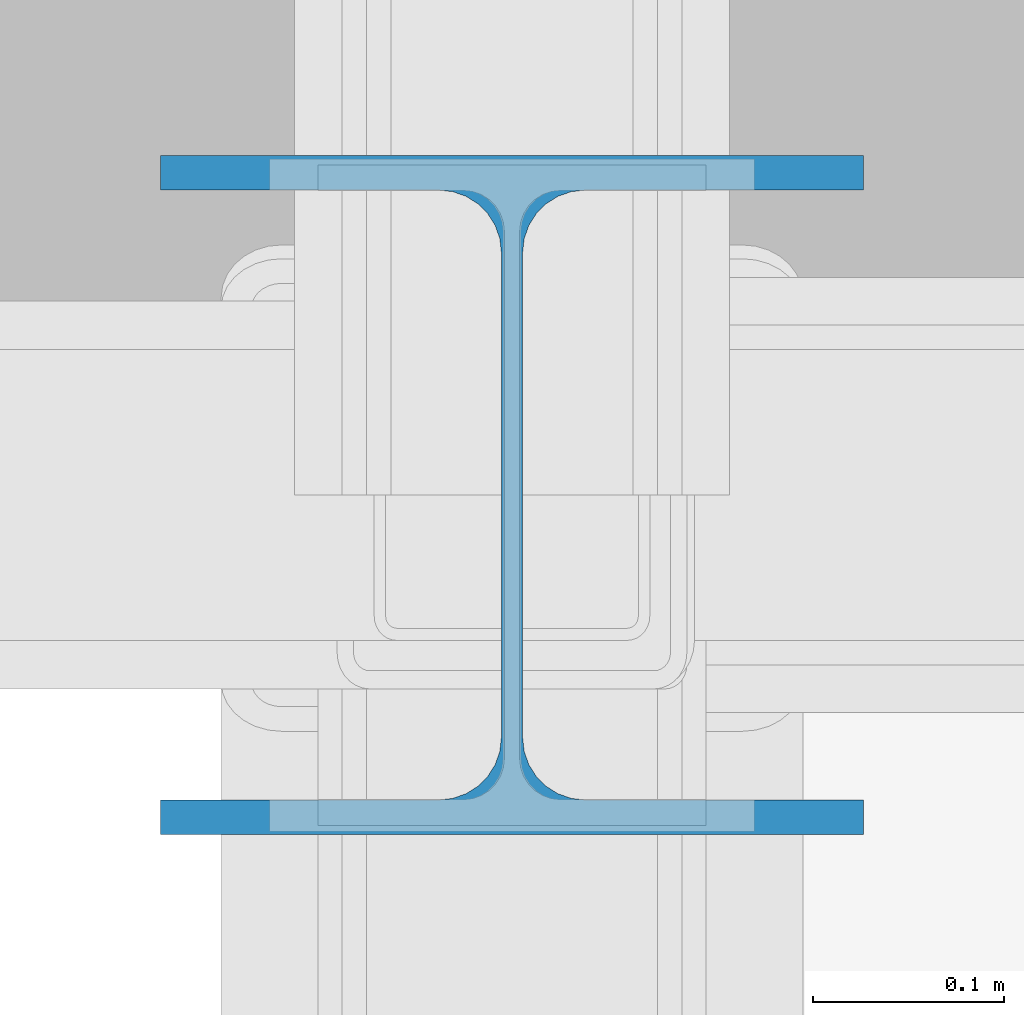
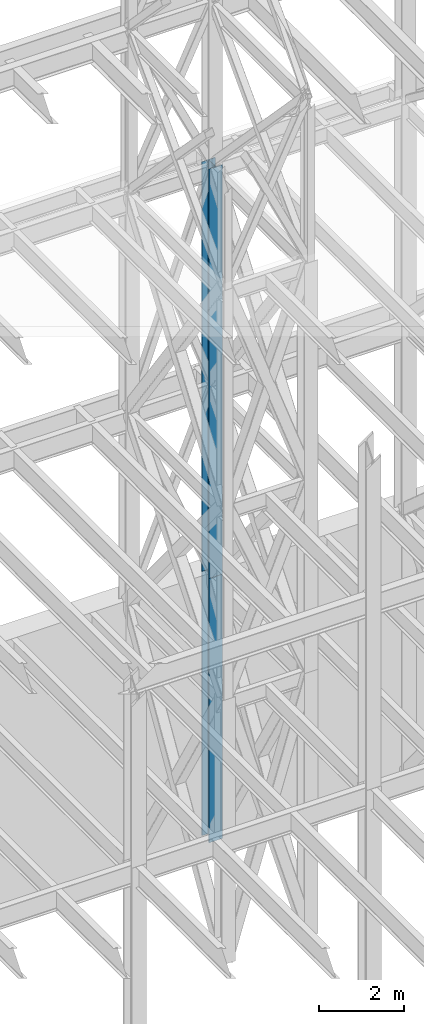
# One storey, part 109 of 150: 2 columns.
"""IFC2X3 building model written with IfcOpenShell, lengths in millimetres."""

from ifc_helpers import new_model, si_unit, frame, origin_with_axes, origin_2d_with_axis, place, context, subcontext, project, spatial, i_section, extrude, material, type_object, element, save


model = new_model("IFC2X3")

# Units and contexts
model_context = context("Model", 3, precision=1e-05, world=origin_with_axes())
body_context = subcontext(model_context, "Body", "Model", "MODEL_VIEW")
ifc_project = project(units=[si_unit("LENGTHUNIT", "METRE", prefix="MILLI"), si_unit("AREAUNIT", "SQUARE_METRE"), si_unit("VOLUMEUNIT", "CUBIC_METRE"), si_unit("MASSUNIT", "GRAM", prefix="KILO"), si_unit("TIMEUNIT", "SECOND"), si_unit("PLANEANGLEUNIT", "RADIAN"), si_unit("SOLIDANGLEUNIT", "STERADIAN"), si_unit("THERMODYNAMICTEMPERATUREUNIT", "DEGREE_CELSIUS"), si_unit("LUMINOUSINTENSITYUNIT", "LUMEN")], contexts=[model_context])

# Site, building, storey
site_placement = place(None, origin_with_axes())
site = spatial("IfcSite", under=ifc_project, at=site_placement, CompositionType="ELEMENT")
building_placement = place(site_placement, origin_with_axes())
building = spatial("IfcBuilding", under=site, at=building_placement, Name="Undefined", CompositionType="ELEMENT")
storey_placement = place(building_placement, origin_with_axes())
storey = spatial("IfcBuildingStorey", under=building, at=storey_placement, Name="Undefined", CompositionType="ELEMENT", Elevation=0.0)

# Columns
ifc_material = material(Name="STEEL/A992")
column_type = type_object("IfcColumnType", Name="W14X90", PredefinedType="NOTDEFINED")
column_1_placement = place(storey_placement, frame((76923.9, 31877.0, 23774.4), z_axis=(0.0, 0.0, 1.0), x_axis=(1.0, 0.0, 0.0)))
element("IfcColumn", 1, at=column_1_placement, inside=storey, type_object=column_type, material=ifc_material, Name="COLUMN", ObjectType="W14X90", context=body_context, shape_type="SweptSolid", body=[
    extrude(i_section(OverallWidth=368.3, OverallDepth=355.6, WebThickness=11.1125, FlangeThickness=18.034, FilletRadius=32.7659, at=origin_2d_with_axis()), frame((0.0, 0.0, 11811.0), z_axis=(0.0, 0.0, -1.0), x_axis=(-1.0, 0.0, 0.0)), (0.0, 0.0, 1.0), 11811.0),
])
column_2_placement = place(storey_placement, frame((76923.9, 31877.0, 16154.4), z_axis=(0.0, 0.0, 1.0), x_axis=(1.0, 0.0, 0.0)))
element("IfcColumn", 2, at=column_2_placement, inside=storey, type_object=column_type, material=ifc_material, Name="COLUMN", ObjectType="W14X90", context=body_context, shape_type="SweptSolid", body=[
    extrude(i_section(OverallWidth=368.3, OverallDepth=355.6, WebThickness=11.1125, FlangeThickness=18.034, FilletRadius=32.7659, at=origin_2d_with_axis()), frame((0.0, 0.0, 7620.0), z_axis=(0.0, 0.0, -1.0), x_axis=(-1.0, 0.0, 0.0)), (0.0, 0.0, 1.0), 7620.0),
])

save(model, "model.ifc")
